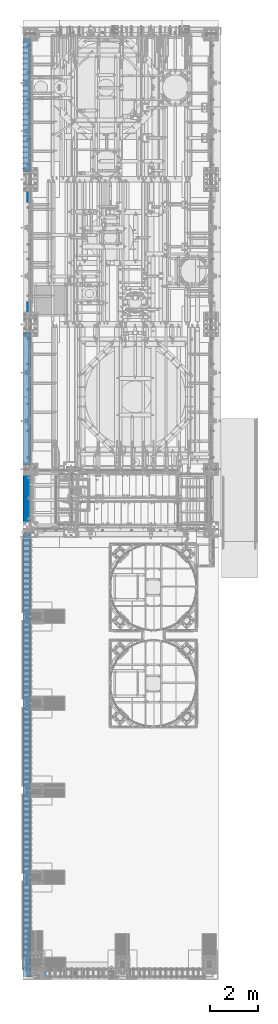
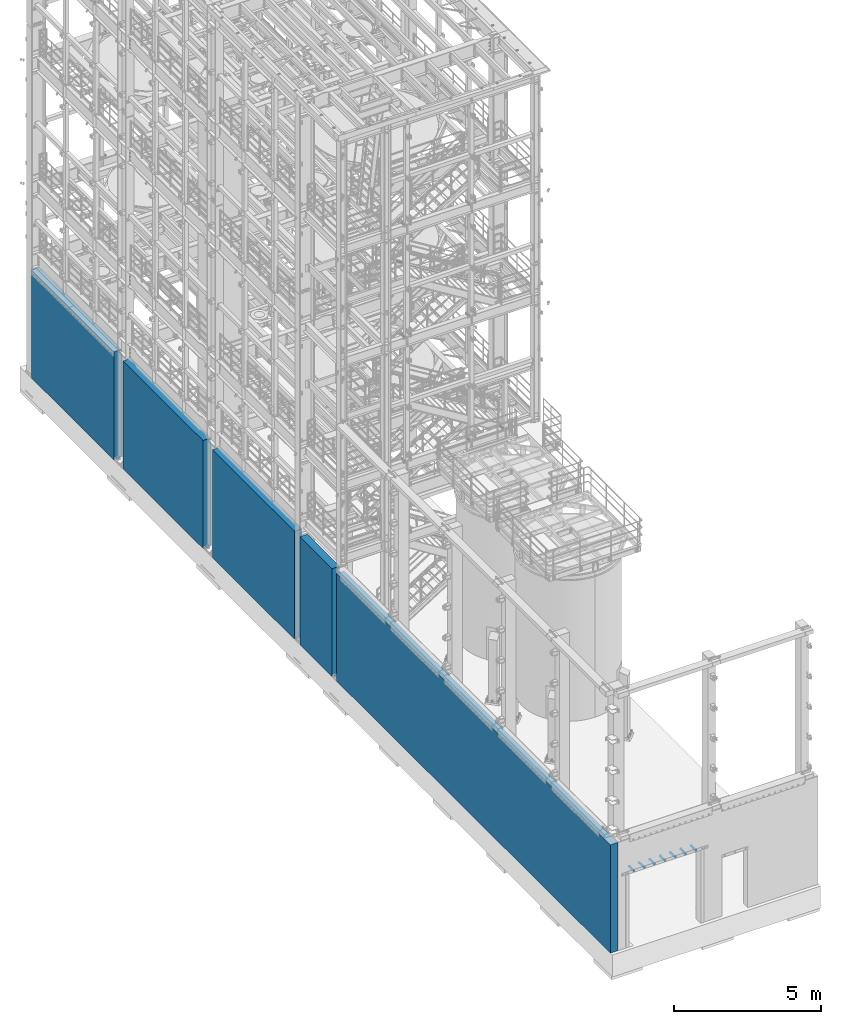
# One storey, part 1 of 1876: 5 walls, 1 mechanical fastener, 6 elements without a shape of their own.
"""IFC2X3 building model written with IfcOpenShell, lengths in millimetres."""

from ifc_helpers import new_model, si_unit, frame, origin_with_axes, place, context, subcontext, project, spatial, faceted_brep, source, transform, mapped, material, type_object, element, aggregate, save


model = new_model("IFC2X3")

# Units and contexts
model_context = context("Model", 3, precision=1e-05, world=origin_with_axes())
body_context = subcontext(model_context, "Body", "Model", "MODEL_VIEW")
ifc_project = project(units=[si_unit("LENGTHUNIT", "METRE", prefix="MILLI"), si_unit("AREAUNIT", "SQUARE_METRE"), si_unit("VOLUMEUNIT", "CUBIC_METRE"), si_unit("MASSUNIT", "GRAM", prefix="KILO"), si_unit("TIMEUNIT", "SECOND"), si_unit("PLANEANGLEUNIT", "RADIAN"), si_unit("SOLIDANGLEUNIT", "STERADIAN"), si_unit("THERMODYNAMICTEMPERATUREUNIT", "DEGREE_CELSIUS"), si_unit("LUMINOUSINTENSITYUNIT", "LUMEN")], contexts=[model_context])

# Site, building, storey
site_placement = place(None, origin_with_axes())
site = spatial("IfcSite", under=ifc_project, at=site_placement, CompositionType="ELEMENT")
building_placement = place(site_placement, origin_with_axes())
building = spatial("IfcBuilding", under=site, at=building_placement, Name="Undefined", CompositionType="ELEMENT")
storey_placement = place(building_placement, origin_with_axes())
storey = spatial("IfcBuildingStorey", under=building, at=storey_placement, Name="Undefined", CompositionType="ELEMENT", Elevation=0.0)

# Assembly, wall
assembly_1_placement = place(storey_placement, origin_with_axes())
assembly_1 = element("IfcElementAssembly", 1, at=assembly_1_placement, inside=storey, Name="WALL", AssemblyPlace="NOTDEFINED", PredefinedType="REINFORCEMENT_UNIT")
ifc_material_1 = material(Name="CONCRETE/5000")
wall_type = type_object("IfcWallType", PredefinedType="NOTDEFINED")
wall_1_placement = place(assembly_1_placement, frame((-144.4625, -4757.7375, 2247.9), z_axis=(0.0, 0.0, 1.0), x_axis=(0.0, -1.0, 0.0)))
wall_1 = element("IfcWall", 2, at=wall_1_placement, type_object=wall_type, material=ifc_material_1, Name="WALL", context=body_context, shape_type="Brep", body=[
    faceted_brep([(0.0, 147.637500000001, -2247.9), (0.0, 147.637500000001, 2247.9), (2198.6875, 147.6375, 2247.9), (2198.6875, 147.6375, -2247.9), (0.0, -147.637500000001, 2247.9), (2198.6875, -147.6375, 2247.9), (0.0, -147.637500000001, -2247.9), (2198.6875, -147.6375, -2247.9)], [[[0, 1, 2, 3]], [[1, 4, 5, 2]], [[4, 6, 7, 5]], [[6, 0, 3, 7]], [[5, 7, 3, 2]], [[6, 4, 1, 0]]]),
])
aggregate(assembly_1, [wall_1])

assembly_2_placement = place(storey_placement, origin_with_axes())
assembly_2 = element("IfcElementAssembly", 3, at=assembly_2_placement, inside=storey, Name="WALL", AssemblyPlace="NOTDEFINED", PredefinedType="REINFORCEMENT_UNIT")
wall_2_placement = place(assembly_2_placement, frame((-144.4625, -7267.575, 2247.9), z_axis=(0.0, 0.0, 1.0), x_axis=(0.0, -1.0, 0.0)))
wall_2 = element("IfcWall", 4, at=wall_2_placement, type_object=wall_type, material=ifc_material_1, Name="WALL", context=body_context, shape_type="Brep", body=[
    faceted_brep([(0.0, 147.637500000001, -2247.9), (0.0, 147.637500000001, 2247.9), (18656.3, 147.6375, 2247.9), (18656.3, 147.6375, -2247.9), (0.0, -147.637500000001, 2247.9), (18656.3, -147.6375, 2247.9), (0.0, -147.637500000001, -2247.9), (18656.3, -147.6375, -2247.9)], [[[0, 1, 2, 3]], [[1, 4, 5, 2]], [[4, 6, 7, 5]], [[6, 0, 3, 7]], [[5, 7, 3, 2]], [[6, 4, 1, 0]]]),
])
aggregate(assembly_2, [wall_2])

assembly_3_placement = place(storey_placement, origin_with_axes())
assembly_3 = element("IfcElementAssembly", 5, at=assembly_3_placement, inside=storey, Name="WALL", AssemblyPlace="NOTDEFINED", PredefinedType="REINFORCEMENT_UNIT")
wall_3_placement = place(assembly_3_placement, frame((-144.4625, 1209.675, 2247.9), z_axis=(0.0, 0.0, 1.0), x_axis=(0.0, -1.0, 0.0)))
wall_3 = element("IfcWall", 6, at=wall_3_placement, type_object=wall_type, material=ifc_material_1, Name="WALL", context=body_context, shape_type="Brep", body=[
    faceted_brep([(0.0, 147.637500000001, -2247.9), (0.0, 147.637500000001, 2247.9), (5595.9375, 147.6375, 2247.9), (5595.9375, 147.6375, -2247.9), (0.0, -147.637500000001, 2247.9), (5595.9375, -147.6375, 2247.9), (0.0, -147.637500000001, -2247.9), (5595.9375, -147.6375, -2247.9)], [[[0, 1, 2, 3]], [[1, 4, 5, 2]], [[4, 6, 7, 5]], [[6, 0, 3, 7]], [[5, 7, 3, 2]], [[6, 4, 1, 0]]]),
])
aggregate(assembly_3, [wall_3])

assembly_4_placement = place(storey_placement, origin_with_axes())
assembly_4 = element("IfcElementAssembly", 7, at=assembly_4_placement, inside=storey, Name="WALL", AssemblyPlace="NOTDEFINED", PredefinedType="REINFORCEMENT_UNIT")
wall_4_placement = place(assembly_4_placement, frame((-144.4625, 7305.675, 2247.9), z_axis=(0.0, 0.0, 1.0), x_axis=(0.0, -1.0, 0.0)))
wall_4 = element("IfcWall", 8, at=wall_4_placement, type_object=wall_type, material=ifc_material_1, Name="WALL", context=body_context, shape_type="Brep", body=[
    faceted_brep([(0.0, 147.637500000001, -2247.9), (0.0, 147.637500000001, 2247.9), (5467.35, 147.6375, 2247.9), (5467.35, 147.6375, -2247.9), (0.0, -147.637500000001, 2247.9), (5467.35, -147.6375, 2247.9), (0.0, -147.637500000001, -2247.9), (5467.35, -147.6375, -2247.9)], [[[0, 1, 2, 3]], [[1, 4, 5, 2]], [[4, 6, 7, 5]], [[6, 0, 3, 7]], [[5, 7, 3, 2]], [[6, 4, 1, 0]]]),
])
aggregate(assembly_4, [wall_4])

assembly_5_placement = place(storey_placement, origin_with_axes())
assembly_5 = element("IfcElementAssembly", 9, at=assembly_5_placement, inside=storey, Name="WALL", AssemblyPlace="NOTDEFINED", PredefinedType="REINFORCEMENT_UNIT")
wall_5_placement = place(assembly_5_placement, frame((-144.4625, 13555.6625, 2247.9), z_axis=(0.0, 0.0, 1.0), x_axis=(0.0, -1.0, 0.0)))
wall_5 = element("IfcWall", 10, at=wall_5_placement, type_object=wall_type, material=ifc_material_1, Name="WALL", context=body_context, shape_type="Brep", body=[
    faceted_brep([(0.0, 147.637500000001, -2247.9), (0.0, 147.637500000001, 2247.9), (5621.3375, 147.6375, 2247.9), (5621.3375, 147.6375, -2247.9), (0.0, -147.637500000001, 2247.9), (5621.3375, -147.6375, 2247.9), (0.0, -147.637500000001, -2247.9), (5621.3375, -147.6375, -2247.9)], [[[0, 1, 2, 3]], [[1, 4, 5, 2]], [[4, 6, 7, 5]], [[6, 0, 3, 7]], [[5, 7, 3, 2]], [[6, 4, 1, 0]]]),
])
aggregate(assembly_5, [wall_5])

# Assembly, mechanical fastener
assembly_6_placement = place(storey_placement, origin_with_axes())
assembly_6 = element("IfcElementAssembly", 11, at=assembly_6_placement, inside=storey, Name="BENT PLATE", AssemblyPlace="NOTDEFINED", PredefinedType="RIGID_FRAME")
ifc_material_2 = material(Name="Undefined")
mechanical_fastener_type = type_object("IfcMechanicalFastenerType", Name="Bolt assembly")
shared_shape = source(origin_with_axes(), body_context, "Body", "Brep", [
    faceted_brep([(10.3187503814697, -157.162490844731, 0.0), (8.93629996566297, -157.162490844731, 5.15937519073517), (5.15937519073425, -157.162490844731, 8.93629996566351), (-1.06936923054691e-12, -157.162490844731, 10.3187503814697), (-5.1593751907361, -157.162490844731, 8.93629996566244), (-8.93629996566404, -157.162490844731, 5.15937519073332), (-10.3187503814697, -157.162490844731, -2.13873846109383e-12), (-8.93629996566191, -157.162490844731, -5.15937519073702), (-5.1593751907324, -157.162490844731, -8.93629996566457), (3.19665157738187e-12, -157.162490844731, -10.3187503814697), (5.15937519073794, -157.162490844731, -8.93629996566137), (8.93629996566511, -157.162490844731, -5.15937519073147), (8.93629996566511, 158.849996948239, -5.15937519073147), (5.15937519073794, 158.849996948239, -8.93629996566137), (3.19665157738187e-12, 158.849996948239, -10.3187503814697), (-5.1593751907324, 158.849996948239, -8.93629996566457), (-8.93629996566191, 158.849996948239, -5.15937519073702), (-10.3187503814697, 158.849996948239, -2.13873846109383e-12), (-8.93629996566404, 158.849996948239, 5.15937519073332), (-5.1593751907361, 158.849996948239, 8.93629996566244), (-1.06936923054691e-12, 158.849996948239, 10.3187503814697), (5.15937519073425, 158.849996948239, 8.93629996566351), (8.93629996566297, 158.849996948239, 5.15937519073517), (10.3187503814697, 158.849996948239, 0.0)], [[[0, 1, 2, 3, 4, 5, 6, 7, 8, 9, 10, 11]], [[12, 13, 14, 15, 16, 17, 18, 19, 20, 21, 22, 23]], [[0, 23, 22, 1]], [[1, 22, 21, 2]], [[2, 21, 20, 3]], [[3, 20, 19, 4]], [[4, 19, 18, 5]], [[5, 18, 17, 6]], [[6, 17, 16, 7]], [[7, 16, 15, 8]], [[8, 15, 14, 9]], [[9, 14, 13, 10]], [[10, 13, 12, 11]], [[11, 12, 23, 0]]]),
])
mechanical_fastener_placement = place(assembly_6_placement, frame((634.999996948242, -25776.2375030518, 3103.56200180057), z_axis=(0.0, 0.0, 1.0), x_axis=(1.0, 0.0, 0.0)))
mechanical_fastener = element("IfcMechanicalFastener", 12, at=mechanical_fastener_placement, type_object=mechanical_fastener_type, material=ifc_material_2, Name="Bolt assembly", NominalDiameter=15.875, NominalLength=330.200012207031, context=body_context, shape_type="MappedRepresentation", body=[
    mapped(shared_shape, transform((0.0, 0.0, 0.0))),
    mapped(shared_shape, transform((406.399993896484, 0.0, 0.0))),
    mapped(shared_shape, transform((812.799987792969, 0.0, 0.0))),
    mapped(shared_shape, transform((1219.19995117188, 0.0, 0.0))),
    mapped(shared_shape, transform((1625.59997558594, 0.0, 0.0))),
    mapped(shared_shape, transform((2032.0, 0.0, 0.0))),
    mapped(shared_shape, transform((2438.39990234375, 0.0, 0.0))),
])
aggregate(assembly_6, [mechanical_fastener])

save(model, "model.ifc")
